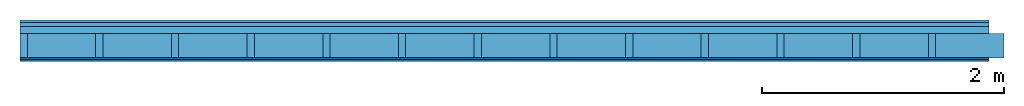
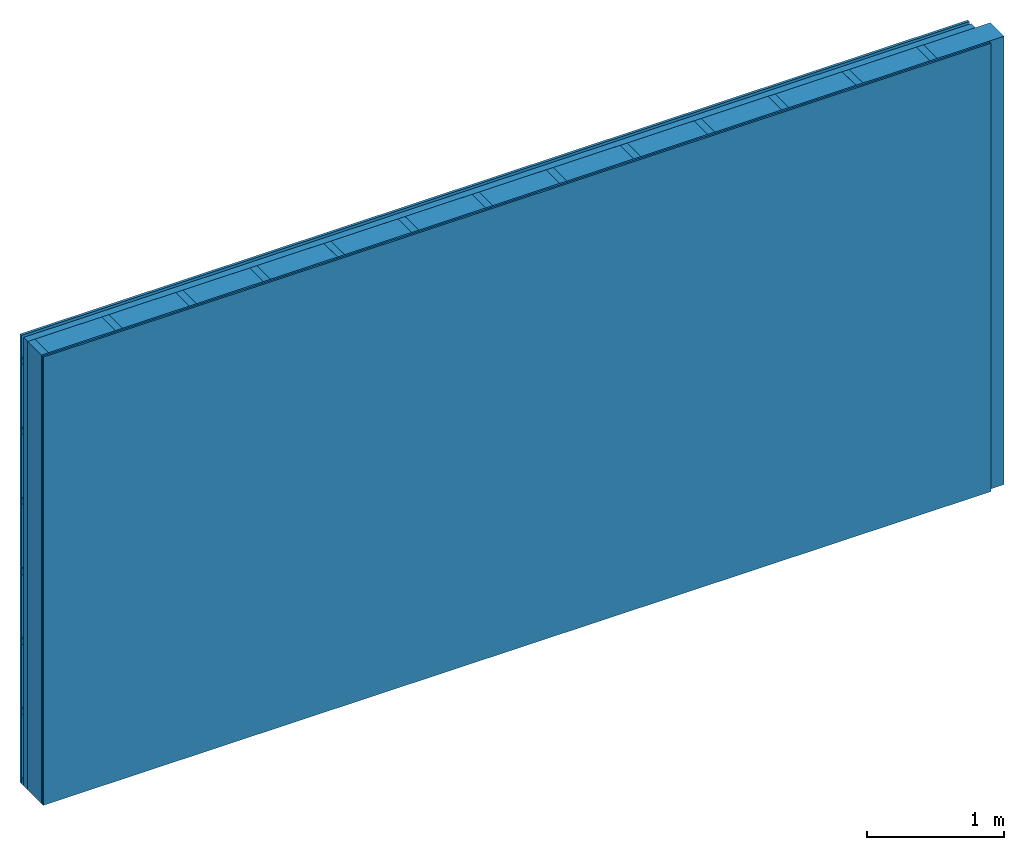
# One storey: 4 plates, 3 members, 1 element without a shape of its own.
"""IFC4 building model written with IfcOpenShell, lengths in metres."""

from ifc_helpers import new_model, si_unit, derived_unit, direction, frame, frame_2d, origin, origin_with_axes, place, context, project, spatial, rectangle, extrude, material, layer, layer_set, type_object, element, aggregate, save


model = new_model("IFC4")

# Units and contexts
plan_context = context("Plan", 3, precision=1e-05, world=origin(), true_north=direction((0.0, 1.0)))
model_context = context("Model", 3, precision=1e-05, world=origin(), true_north=direction((0.0, 1.0)))
ifc_project = project(units=[si_unit("LENGTHUNIT", "METRE"), derived_unit("SOUNDPRESSUREUNIT", [(si_unit("PRESSUREUNIT", "PASCAL", prefix="MICRO"), 0)]), si_unit("ENERGYUNIT", "JOULE", prefix="MEGA"), si_unit("MASSUNIT", "GRAM", prefix="KILO"), derived_unit("THERMALTRANSMITTANCEUNIT", [(si_unit("POWERUNIT", "WATT"), 1), (si_unit("AREAUNIT", "SQUARE_METRE"), -1), (si_unit("THERMODYNAMICTEMPERATUREUNIT", "KELVIN"), -1)]), derived_unit("AREADENSITYUNIT", [(si_unit("MASSUNIT", "GRAM", prefix="KILO"), 1), (si_unit("AREAUNIT", "SQUARE_METRE"), -1)]), derived_unit("USERDEFINED", [(si_unit("ENERGYUNIT", "JOULE", prefix="MEGA"), 1), (si_unit("AREAUNIT", "SQUARE_METRE"), -1)])], contexts=[plan_context, model_context])

# Site, building, storey
site = spatial("IfcSite", under=ifc_project)
building_placement = place(None, origin())
building = spatial("IfcBuilding", under=site, at=building_placement)
storey_placement = place(building_placement, origin())
storey = spatial("IfcBuildingStorey", under=building, at=storey_placement)

# Wall, members, plates
ifc_material_1 = material(Name="Wood cladding horizontal, closed")
ifc_layer_1 = layer(ifc_material_1, 0.022, Name="Cover 1st layer")
ifc_layer_2 = layer(None, 0.03, Name="Battens / profiles (ventilation)")
ifc_material_2 = material(Category="10.009")
ifc_layer_3 = layer(ifc_material_2, 0.06, Name="outside 2nd layer")
ifc_material_3 = material(Name="of the art")
ifc_layer_4 = layer(ifc_material_3, 0.0, Name="Bond")
ifc_layer_5 = layer(None, 0.2, Name="Support")
ifc_layer_6 = layer(ifc_material_3, 0.0, Name="Bond")
ifc_material_4 = material(Category="03.007")
ifc_layer_7 = layer(ifc_material_4, 0.015, Name="1st layer")
ifc_layer_8 = layer(ifc_material_4, 0.015, Name="2nd layer")
ifc_material_5 = material(Name="Glued joints")
ifc_layer_9 = layer(ifc_material_5, 0.0, Name="Surface")
ifc_layer_set = layer_set([ifc_layer_1, ifc_layer_2, ifc_layer_3, ifc_layer_4, ifc_layer_5, ifc_layer_6, ifc_layer_7, ifc_layer_8, ifc_layer_9])
wall_type = type_object("IfcWallType", Name="D0107", PredefinedType="NOTDEFINED", material=ifc_layer_set)
wall_placement = place(None, frame((0.0, 0.0, 0.0), z_axis=(0.0, -1.0, 0.0), x_axis=(1.0, 0.0, 0.0)))
wall = element("IfcWall", 1, at=wall_placement, inside=storey, type_object=wall_type, material=ifc_layer_set, Name="Wall #1")
ifc_material_6 = material()
member_1_placement = place(wall_placement, origin())
member_1 = element("IfcMember", 2, at=member_1_placement, material=ifc_material_6, Name="Battens / profiles (ventilation)", context=plan_context, shape_type="SweptSolid", body=[
    extrude(rectangle(XDim=0.05, YDim=0.03, at=frame_2d((0.025, 0.015), x_axis=(1.0, 0.0))), frame((0.0, 0.0, 0.022), z_axis=(1.0, 0.0, 0.0), x_axis=(0.0, 1.0, 0.0)), (0.0, 0.0, 1.0), 8.0),
    extrude(rectangle(XDim=0.05, YDim=0.03, at=frame_2d((0.025, 0.015), x_axis=(1.0, 0.0))), frame((0.0, 0.625, 0.022), z_axis=(1.0, 0.0, 0.0), x_axis=(0.0, 1.0, 0.0)), (0.0, 0.0, 1.0), 8.0),
    extrude(rectangle(XDim=0.05, YDim=0.03, at=frame_2d((0.025, 0.015), x_axis=(1.0, 0.0))), frame((0.0, 1.25, 0.022), z_axis=(1.0, 0.0, 0.0), x_axis=(0.0, 1.0, 0.0)), (0.0, 0.0, 1.0), 8.0),
    extrude(rectangle(XDim=0.05, YDim=0.03, at=frame_2d((0.025, 0.015), x_axis=(1.0, 0.0))), frame((0.0, 1.875, 0.022), z_axis=(1.0, 0.0, 0.0), x_axis=(0.0, 1.0, 0.0)), (0.0, 0.0, 1.0), 8.0),
    extrude(rectangle(XDim=0.05, YDim=0.03, at=frame_2d((0.025, 0.015), x_axis=(1.0, 0.0))), frame((0.0, 2.5, 0.022), z_axis=(1.0, 0.0, 0.0), x_axis=(0.0, 1.0, 0.0)), (0.0, 0.0, 1.0), 8.0),
    extrude(rectangle(XDim=0.05, YDim=0.03, at=frame_2d((0.025, 0.015), x_axis=(1.0, 0.0))), frame((0.0, 3.125, 0.022), z_axis=(1.0, 0.0, 0.0), x_axis=(0.0, 1.0, 0.0)), (0.0, 0.0, 1.0), 8.0),
    extrude(rectangle(XDim=0.05, YDim=0.03, at=frame_2d((0.025, 0.015), x_axis=(1.0, 0.0))), frame((0.0, 3.75, 0.022), z_axis=(1.0, 0.0, 0.0), x_axis=(0.0, 1.0, 0.0)), (0.0, 0.0, 1.0), 8.0),
])
ifc_material_7 = material()
member_2_placement = place(wall_placement, origin())
member_2 = element("IfcMember", 3, at=member_2_placement, material=ifc_material_7, Name="Support", context=plan_context, shape_type="SweptSolid", body=[
    extrude(rectangle(XDim=0.06, YDim=0.2, at=frame_2d((0.03, 0.1), x_axis=(1.0, 0.0))), frame((0.0, 4.0, 0.112), z_axis=(0.0, -1.0, 0.0), x_axis=(1.0, 0.0, 0.0)), (0.0, 0.0, 1.0), 4.0),
    extrude(rectangle(XDim=0.06, YDim=0.2, at=frame_2d((0.03, 0.1), x_axis=(1.0, 0.0))), frame((0.625, 4.0, 0.112), z_axis=(0.0, -1.0, 0.0), x_axis=(1.0, 0.0, 0.0)), (0.0, 0.0, 1.0), 4.0),
    extrude(rectangle(XDim=0.06, YDim=0.2, at=frame_2d((0.03, 0.1), x_axis=(1.0, 0.0))), frame((1.25, 4.0, 0.112), z_axis=(0.0, -1.0, 0.0), x_axis=(1.0, 0.0, 0.0)), (0.0, 0.0, 1.0), 4.0),
    extrude(rectangle(XDim=0.06, YDim=0.2, at=frame_2d((0.03, 0.1), x_axis=(1.0, 0.0))), frame((1.875, 4.0, 0.112), z_axis=(0.0, -1.0, 0.0), x_axis=(1.0, 0.0, 0.0)), (0.0, 0.0, 1.0), 4.0),
    extrude(rectangle(XDim=0.06, YDim=0.2, at=frame_2d((0.03, 0.1), x_axis=(1.0, 0.0))), frame((2.5, 4.0, 0.112), z_axis=(0.0, -1.0, 0.0), x_axis=(1.0, 0.0, 0.0)), (0.0, 0.0, 1.0), 4.0),
    extrude(rectangle(XDim=0.06, YDim=0.2, at=frame_2d((0.03, 0.1), x_axis=(1.0, 0.0))), frame((3.125, 4.0, 0.112), z_axis=(0.0, -1.0, 0.0), x_axis=(1.0, 0.0, 0.0)), (0.0, 0.0, 1.0), 4.0),
    extrude(rectangle(XDim=0.06, YDim=0.2, at=frame_2d((0.03, 0.1), x_axis=(1.0, 0.0))), frame((3.75, 4.0, 0.112), z_axis=(0.0, -1.0, 0.0), x_axis=(1.0, 0.0, 0.0)), (0.0, 0.0, 1.0), 4.0),
    extrude(rectangle(XDim=0.06, YDim=0.2, at=frame_2d((0.03, 0.1), x_axis=(1.0, 0.0))), frame((4.375, 4.0, 0.112), z_axis=(0.0, -1.0, 0.0), x_axis=(1.0, 0.0, 0.0)), (0.0, 0.0, 1.0), 4.0),
    extrude(rectangle(XDim=0.06, YDim=0.2, at=frame_2d((0.03, 0.1), x_axis=(1.0, 0.0))), frame((5.0, 4.0, 0.112), z_axis=(0.0, -1.0, 0.0), x_axis=(1.0, 0.0, 0.0)), (0.0, 0.0, 1.0), 4.0),
    extrude(rectangle(XDim=0.06, YDim=0.2, at=frame_2d((0.03, 0.1), x_axis=(1.0, 0.0))), frame((5.625, 4.0, 0.112), z_axis=(0.0, -1.0, 0.0), x_axis=(1.0, 0.0, 0.0)), (0.0, 0.0, 1.0), 4.0),
    extrude(rectangle(XDim=0.06, YDim=0.2, at=frame_2d((0.03, 0.1), x_axis=(1.0, 0.0))), frame((6.25, 4.0, 0.112), z_axis=(0.0, -1.0, 0.0), x_axis=(1.0, 0.0, 0.0)), (0.0, 0.0, 1.0), 4.0),
    extrude(rectangle(XDim=0.06, YDim=0.2, at=frame_2d((0.03, 0.1), x_axis=(1.0, 0.0))), frame((6.875, 4.0, 0.112), z_axis=(0.0, -1.0, 0.0), x_axis=(1.0, 0.0, 0.0)), (0.0, 0.0, 1.0), 4.0),
    extrude(rectangle(XDim=0.06, YDim=0.2, at=frame_2d((0.03, 0.1), x_axis=(1.0, 0.0))), frame((7.5, 4.0, 0.112), z_axis=(0.0, -1.0, 0.0), x_axis=(1.0, 0.0, 0.0)), (0.0, 0.0, 1.0), 4.0),
])
ifc_material_8 = material()
member_3_placement = place(wall_placement, origin())
member_3 = element("IfcMember", 4, at=member_3_placement, material=ifc_material_8, Name="Cavity", context=plan_context, shape_type="SweptSolid", body=[
    extrude(rectangle(XDim=0.565, YDim=0.2, at=frame_2d((0.2825, 0.1), x_axis=(1.0, 0.0))), frame((0.06, 4.0, 0.112), z_axis=(0.0, -1.0, 0.0), x_axis=(1.0, 0.0, 0.0)), (0.0, 0.0, 1.0), 4.0),
    extrude(rectangle(XDim=0.565, YDim=0.2, at=frame_2d((0.2825, 0.1), x_axis=(1.0, 0.0))), frame((0.685, 4.0, 0.112), z_axis=(0.0, -1.0, 0.0), x_axis=(1.0, 0.0, 0.0)), (0.0, 0.0, 1.0), 4.0),
    extrude(rectangle(XDim=0.565, YDim=0.2, at=frame_2d((0.2825, 0.1), x_axis=(1.0, 0.0))), frame((1.31, 4.0, 0.112), z_axis=(0.0, -1.0, 0.0), x_axis=(1.0, 0.0, 0.0)), (0.0, 0.0, 1.0), 4.0),
    extrude(rectangle(XDim=0.565, YDim=0.2, at=frame_2d((0.2825, 0.1), x_axis=(1.0, 0.0))), frame((1.935, 4.0, 0.112), z_axis=(0.0, -1.0, 0.0), x_axis=(1.0, 0.0, 0.0)), (0.0, 0.0, 1.0), 4.0),
    extrude(rectangle(XDim=0.565, YDim=0.2, at=frame_2d((0.2825, 0.1), x_axis=(1.0, 0.0))), frame((2.56, 4.0, 0.112), z_axis=(0.0, -1.0, 0.0), x_axis=(1.0, 0.0, 0.0)), (0.0, 0.0, 1.0), 4.0),
    extrude(rectangle(XDim=0.565, YDim=0.2, at=frame_2d((0.2825, 0.1), x_axis=(1.0, 0.0))), frame((3.185, 4.0, 0.112), z_axis=(0.0, -1.0, 0.0), x_axis=(1.0, 0.0, 0.0)), (0.0, 0.0, 1.0), 4.0),
    extrude(rectangle(XDim=0.565, YDim=0.2, at=frame_2d((0.2825, 0.1), x_axis=(1.0, 0.0))), frame((3.81, 4.0, 0.112), z_axis=(0.0, -1.0, 0.0), x_axis=(1.0, 0.0, 0.0)), (0.0, 0.0, 1.0), 4.0),
    extrude(rectangle(XDim=0.565, YDim=0.2, at=frame_2d((0.2825, 0.1), x_axis=(1.0, 0.0))), frame((4.435, 4.0, 0.112), z_axis=(0.0, -1.0, 0.0), x_axis=(1.0, 0.0, 0.0)), (0.0, 0.0, 1.0), 4.0),
    extrude(rectangle(XDim=0.565, YDim=0.2, at=frame_2d((0.2825, 0.1), x_axis=(1.0, 0.0))), frame((5.06, 4.0, 0.112), z_axis=(0.0, -1.0, 0.0), x_axis=(1.0, 0.0, 0.0)), (0.0, 0.0, 1.0), 4.0),
    extrude(rectangle(XDim=0.565, YDim=0.2, at=frame_2d((0.2825, 0.1), x_axis=(1.0, 0.0))), frame((5.685, 4.0, 0.112), z_axis=(0.0, -1.0, 0.0), x_axis=(1.0, 0.0, 0.0)), (0.0, 0.0, 1.0), 4.0),
    extrude(rectangle(XDim=0.565, YDim=0.2, at=frame_2d((0.2825, 0.1), x_axis=(1.0, 0.0))), frame((6.31, 4.0, 0.112), z_axis=(0.0, -1.0, 0.0), x_axis=(1.0, 0.0, 0.0)), (0.0, 0.0, 1.0), 4.0),
    extrude(rectangle(XDim=0.565, YDim=0.2, at=frame_2d((0.2825, 0.1), x_axis=(1.0, 0.0))), frame((6.935, 4.0, 0.112), z_axis=(0.0, -1.0, 0.0), x_axis=(1.0, 0.0, 0.0)), (0.0, 0.0, 1.0), 4.0),
    extrude(rectangle(XDim=0.565, YDim=0.2, at=frame_2d((0.2825, 0.1), x_axis=(1.0, 0.0))), frame((7.56, 4.0, 0.112), z_axis=(0.0, -1.0, 0.0), x_axis=(1.0, 0.0, 0.0)), (0.0, 0.0, 1.0), 4.0),
])
plate_1_placement = place(wall_placement, origin())
plate_1 = element("IfcPlate", 5, at=plate_1_placement, material=ifc_material_1, Name="Cover 1st layer", context=plan_context, shape_type="SweptSolid", body=[
    extrude(rectangle(XDim=8.0, YDim=4.0, at=frame_2d((4.0, 2.0), x_axis=(1.0, 0.0))), origin_with_axes(), (0.0, 0.0, 1.0), 0.022),
])
plate_2_placement = place(wall_placement, origin())
plate_2 = element("IfcPlate", 6, at=plate_2_placement, material=ifc_material_2, Name="outside 2nd layer", context=plan_context, shape_type="SweptSolid", body=[
    extrude(rectangle(XDim=8.0, YDim=4.0, at=frame_2d((4.0, 2.0), x_axis=(1.0, 0.0))), frame((0.0, 0.0, 0.052), z_axis=(0.0, 0.0, 1.0), x_axis=(1.0, 0.0, 0.0)), (0.0, 0.0, 1.0), 0.06),
])
plate_3_placement = place(wall_placement, origin())
plate_3 = element("IfcPlate", 7, at=plate_3_placement, material=ifc_material_4, Name="1st layer", context=plan_context, shape_type="SweptSolid", body=[
    extrude(rectangle(XDim=8.0, YDim=4.0, at=frame_2d((4.0, 2.0), x_axis=(1.0, 0.0))), frame((0.0, 0.0, 0.312), z_axis=(0.0, 0.0, 1.0), x_axis=(1.0, 0.0, 0.0)), (0.0, 0.0, 1.0), 0.015),
])
plate_4_placement = place(wall_placement, origin())
plate_4 = element("IfcPlate", 8, at=plate_4_placement, material=ifc_material_4, Name="2nd layer", context=plan_context, shape_type="SweptSolid", body=[
    extrude(rectangle(XDim=8.0, YDim=4.0, at=frame_2d((4.0, 2.0), x_axis=(1.0, 0.0))), frame((0.0, 0.0, 0.327), z_axis=(0.0, 0.0, 1.0), x_axis=(1.0, 0.0, 0.0)), (0.0, 0.0, 1.0), 0.015),
])
aggregate(wall, [plate_1, member_1, plate_2, member_2, member_3, plate_3, plate_4])

save(model, "model.ifc")
